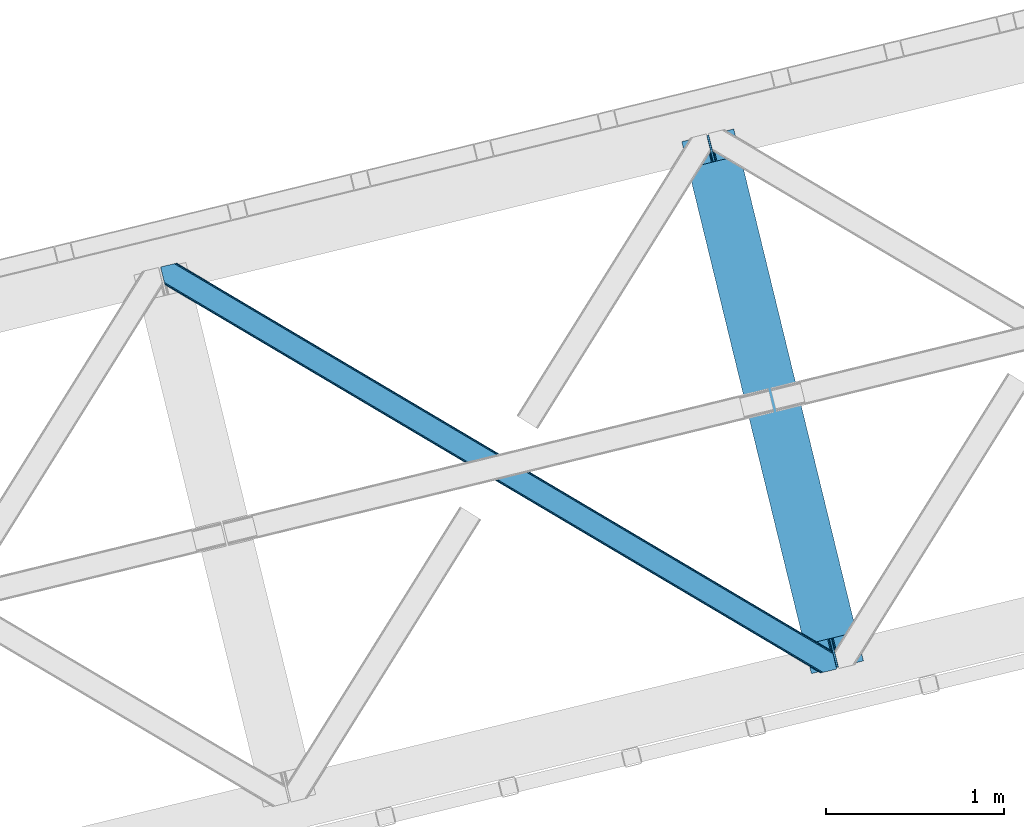
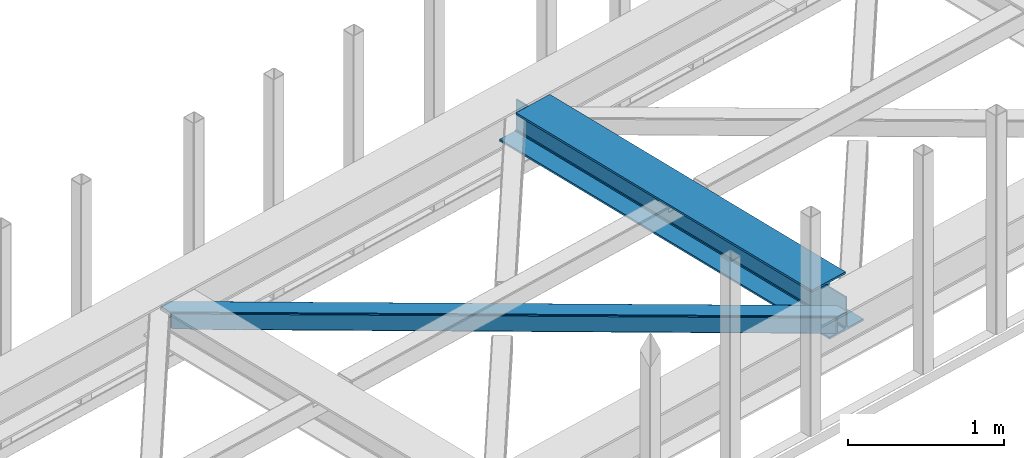
# One storey, part 47 of 67: 1 beam, 1 member.
"""IFC4 building model written with IfcOpenShell, lengths in millimetres."""

from ifc_helpers import new_model, entity, si_unit, converted_unit, derived_unit, direction, frame, origin, place, context, subcontext, project, spatial, triangles, polygons, material, type_object, element, save


model = new_model("IFC4")

# Units and contexts
model_context = context("Model", 3, precision=0.01, world=origin(), true_north=direction((6.12303176911189e-17, 1.0)))
plan_context = context("Plan", 3, precision=0.01, world=origin(), true_north=direction((6.12303176911189e-17, 1.0)))
body_context = subcontext(model_context, "Body", "Model", "MODEL_VIEW")
ifc_project = project(units=[si_unit("LENGTHUNIT", "METRE", prefix="MILLI"), si_unit("AREAUNIT", "SQUARE_METRE"), si_unit("VOLUMEUNIT", "CUBIC_METRE"), converted_unit("PLANEANGLEUNIT", "DEGREE", entity("IfcRatioMeasure", 0.0174532925199433), si_unit("PLANEANGLEUNIT", "RADIAN"), dimensions=[0, 0, 0, 0, 0, 0, 0]), si_unit("MASSUNIT", "GRAM", prefix="KILO"), derived_unit("MASSDENSITYUNIT", [(si_unit("MASSUNIT", "GRAM", prefix="KILO"), 1), (si_unit("LENGTHUNIT", "METRE"), -3)]), derived_unit("MOMENTOFINERTIAUNIT", [(si_unit("LENGTHUNIT", "METRE"), 4)]), si_unit("TIMEUNIT", "SECOND"), si_unit("FREQUENCYUNIT", "HERTZ"), si_unit("THERMODYNAMICTEMPERATUREUNIT", "DEGREE_CELSIUS"), derived_unit("THERMALTRANSMITTANCEUNIT", [(si_unit("MASSUNIT", "GRAM", prefix="KILO"), 1), (si_unit("THERMODYNAMICTEMPERATUREUNIT", "KELVIN"), -1), (si_unit("TIMEUNIT", "SECOND"), -3)]), derived_unit("VOLUMETRICFLOWRATEUNIT", [(si_unit("LENGTHUNIT", "METRE"), 3), (si_unit("TIMEUNIT", "SECOND"), -1)]), derived_unit("MASSFLOWRATEUNIT", [(si_unit("MASSUNIT", "GRAM", prefix="KILO"), 1), (si_unit("TIMEUNIT", "SECOND"), -1)]), derived_unit("ROTATIONALFREQUENCYUNIT", [(si_unit("TIMEUNIT", "SECOND"), -1)]), si_unit("ELECTRICCURRENTUNIT", "AMPERE"), si_unit("ELECTRICVOLTAGEUNIT", "VOLT"), si_unit("POWERUNIT", "WATT"), si_unit("FORCEUNIT", "NEWTON", prefix="KILO"), si_unit("ILLUMINANCEUNIT", "LUX"), si_unit("LUMINOUSFLUXUNIT", "LUMEN"), si_unit("LUMINOUSINTENSITYUNIT", "CANDELA"), derived_unit("USERDEFINED", [(si_unit("MASSUNIT", "GRAM", prefix="KILO"), -1), (si_unit("LENGTHUNIT", "METRE"), -2), (si_unit("TIMEUNIT", "SECOND"), 3), (si_unit("LUMINOUSFLUXUNIT", "LUMEN"), 1)]), derived_unit("LINEARVELOCITYUNIT", [(si_unit("LENGTHUNIT", "METRE"), 1), (si_unit("TIMEUNIT", "SECOND"), -1)]), si_unit("PRESSUREUNIT", "PASCAL"), derived_unit("USERDEFINED", [(si_unit("LENGTHUNIT", "METRE"), -2), (si_unit("MASSUNIT", "GRAM", prefix="KILO"), 1), (si_unit("TIMEUNIT", "SECOND"), -2)]), derived_unit("LINEARFORCEUNIT", [(si_unit("MASSUNIT", "GRAM", prefix="KILO"), 1), (si_unit("LENGTHUNIT", "METRE"), 1), (si_unit("TIMEUNIT", "SECOND"), -2), (si_unit("LENGTHUNIT", "METRE"), -1)]), derived_unit("PLANARFORCEUNIT", [(si_unit("MASSUNIT", "GRAM", prefix="KILO"), 1), (si_unit("LENGTHUNIT", "METRE"), 1), (si_unit("TIMEUNIT", "SECOND"), -2), (si_unit("LENGTHUNIT", "METRE"), -2)])], contexts=[model_context, plan_context])

# Site, building, storey
site_placement = place(None, origin())
site = spatial("IfcSite", under=ifc_project, at=site_placement, CompositionType="ELEMENT")
building_placement = place(site_placement, origin())
building = spatial("IfcBuilding", under=site, at=building_placement, CompositionType="ELEMENT")
storey_placement = place(building_placement, frame((0.0, 0.0, 19800.0)))
storey = spatial("IfcBuildingStorey", under=building, at=storey_placement, CompositionType="ELEMENT", Elevation=19800.0)

# Beam
ifc_material = material(Name="Metal painted (White)")
beam_type = type_object("IfcBeamType", PredefinedType="BEAM")
beam_placement = place(storey_placement, frame((-14954.5071311778, 14149.6098838578, 3807.02022389142)))
element("IfcBeam", 1, at=beam_placement, inside=storey, type_object=beam_type, material=ifc_material, ObjectType="Steel Beam", PredefinedType="BEAM", context=body_context, shape_type="Tessellation", body=[
    polygons([(1018.1664837833, 71.0478278971043, 15.5000000000008), (1018.16648378329, 71.0478278971043, 0.0), (291.465617442446, 3052.25531830422, 0.0), (291.465617442448, 3052.25531830422, 15.5000000000008), (894.779372399329, 40.9709140873291, 15.5000000000008), (168.078506058476, 3022.17840449444, 15.5000000000008), (888.087028625377, 39.3395844888265, 16.8701684147984), (161.386162284526, 3020.54707489594, 16.8701684147984), (882.413533524757, 37.9566100336519, 20.7720779386434), (155.712667183904, 3019.16410044077, 20.7720779386434), (878.622625296178, 37.0325360459162, 26.6116982174294), (151.921758955329, 3018.24002645303, 26.6116982174294), (877.291435352781, 36.7080444135051, 33.500000000001), (150.59056901193, 3017.91553482062, 33.500000000001), (140.875048430516, 3015.54727389071, 33.500000000001), (140.875048430512, 3015.54727389071, 259.000000000002), (150.590569011935, 3017.91553482062, 259.000000000002), (0.0, 2981.20749040711, 0.0), (0.0, 2981.20749040711, 15.4999999999965), (123.387111383964, 3011.28440421689, 15.5000000000008), (130.079455157924, 3012.91573381539, 16.8701684147941), (135.752950258549, 3014.29870827056, 20.7720779386434), (139.543858487119, 3015.2227822583, 26.6116982174294), (877.291435352788, 36.7080444135051, 259.000000000002), (867.575914771362, 34.3397834835992, 259.000000000002), (867.575914771367, 34.3397834835992, 33.500000000001), (866.24472482797, 34.0152918511859, 26.6116982174294), (862.453816599399, 33.0912178634524, 20.7720779386434), (856.780321498773, 31.70824340828, 16.8701684147941), (850.087977724817, 30.0769138097752, 15.5000000000008), (726.700866340853, 2.16573425859679e-12, 15.4999999999965), (726.700866340853, 2.16573425859679e-12, 0.0), (838.124523615921, 197.385937999185, 259.069791973884), (186.46972209998, 2870.72539801219, 259.000000000002), (186.693115201831, 2869.80895360721, 259.617303331124), (186.705504045461, 2869.75812937344, 266.500003008253), (837.979344808156, 197.981416001706, 266.500002998871), (837.979694928908, 197.979979696975, 260.000004007589), (828.499586345868, 194.645865944432, 259.006343171919), (828.276216326105, 195.562317481911, 259.617303331124), (828.263827482477, 195.613141715687, 266.500003008253), (176.989986719777, 2867.38985508742, 266.500002998871), (176.989636599025, 2867.39129139215, 260.000004007589), (176.844830940683, 2867.98534020594, 259.07612046749), (176.754201518552, 2868.35713708228, 259.000000000002), (839.310832678068, 198.30468544639, 273.388305639783), (843.101109266764, 199.231350618306, 279.227924098781), (848.7741802143, 200.616065081981, 283.129832400619), (855.466371895425, 202.248018612794, 284.500000377224), (978.853400583271, 232.325271667903, 284.500000138971), (978.85173077662, 232.332121736637, 299.999995328161), (687.386308679347, 161.283492472596, 299.999995890962), (687.387978485999, 161.276642403865, 284.500000701776), (810.775007173843, 191.353895458974, 284.500000463519), (817.467494069984, 192.984637925553, 283.129832461069), (823.141405718757, 194.365903570081, 279.227924137322), (826.93294050574, 195.287407219377, 273.388305663684), (175.658498849859, 2867.06658564273, 273.388305639783), (171.868222261169, 2866.13992047082, 279.227924098781), (166.195151313624, 2864.75520600714, 283.129832400619), (159.502959632495, 2863.12325247633, 284.500000377228), (36.1159309446555, 2833.04599942122, 284.500000138971), (36.117600751305, 2833.03914935249, 299.999995328161), (327.583022848578, 2904.08777861653, 299.999995890962), (327.58135304193, 2904.09462868526, 284.500000701776), (204.194324354077, 2874.01737563015, 284.500000463519), (197.501837457941, 2872.38663316357, 283.129832461069), (191.827925809181, 2871.00536751905, 279.227924137322), (188.036391022187, 2870.08386386975, 273.388305663684)], [[[1, 2, 3, 4]], [[5, 1, 4, 6]], [[7, 5, 6, 8]], [[9, 7, 8, 10]], [[11, 9, 10, 12]], [[13, 11, 12, 14]], [[15, 16, 17, 14, 12, 10, 8, 6, 4, 3, 18, 19, 20, 21, 22, 23]], [[13, 24, 25, 26, 27, 28, 29, 30, 31, 32, 2, 1, 5, 7, 9, 11]], [[2, 32, 18, 3]], [[32, 31, 19, 18]], [[31, 30, 20, 19]], [[27, 26, 15, 23]], [[28, 27, 23, 22]], [[29, 28, 22, 21]], [[30, 29, 21, 20]], [[33, 24, 13, 14, 17, 34, 35, 36, 37, 38]], [[25, 39, 40, 41, 42, 43, 44, 16, 15, 26]], [[39, 25, 24, 33]], [[45, 34, 17, 16]], [[41, 40, 38, 37, 46, 47, 48, 49, 50, 51, 52, 53, 54, 55, 56, 57]], [[42, 58, 59, 60, 61, 62, 63, 64, 65, 66, 67, 68, 69, 36, 35, 43]], [[46, 37, 36, 69]], [[47, 46, 69, 68]], [[48, 47, 68, 67]], [[49, 48, 67, 66]], [[50, 49, 66, 65]], [[51, 50, 65, 64]], [[52, 51, 64, 63]], [[53, 52, 63, 62]], [[54, 53, 62, 61]], [[55, 54, 61, 60]], [[56, 55, 60, 59]], [[57, 56, 59, 58]], [[41, 57, 58, 42]]], closed=False),
])

# Member
member_type = type_object("IfcMemberType", PredefinedType="BRACE")
member_placement = place(storey_placement, frame((-17875.1786865234, 14152.6640441895, 3822.99993896484)))
element("IfcMember", 2, at=member_placement, inside=storey, type_object=member_type, ObjectType="Steel Horizontal Brace", PredefinedType="BRACE", context=body_context, shape_type="Tessellation", body=[
    triangles([(3167.12412414551, 476.930191040039, 17.5012573242202), (3764.84577941895, 123.065744018553, 122.499499511719), (3764.84577941895, 123.065744018553, 17.5012573242202), (2547.33172302246, 843.862445068358, 17.5012573242202), (1927.53932189941, 1210.79469909668, 17.5012573242202), (91.5002288818359, 2297.77602539063, 122.499499511719), (687.954519653322, 1944.65804443359, 17.5012573242202), (91.5002288818359, 2297.77602539063, 17.5012573242202), (1307.74692077637, 1577.726953125, 17.5012573242202), (3770.63961181641, 99.2985900878903, 140.00075683594), (3768.42230529785, 108.393383789062, 138.668280029298), (76.4767272949211, 2294.11345825195, 138.668280029298), (67.1679931640647, 2291.84499206543, 140.00075683594), (3766.54335021973, 116.104541015624, 134.87548828125), (84.3704315185569, 2296.03775939941, 134.87548828125), (3765.28761291504, 121.256552124023, 129.196765136719), (89.6480163574233, 2297.32489013672, 129.196765136719), (3722.23907775879, 5.93219604492151, 140.00075683594), (18.767459106446, 2198.47859802246, 140.00075683594), (3789.40707092285, 22.304452514647, 140.00075683594), (0.0, 2275.47157287597, 140.00075683594), (3697.90684204102, 0.0, 122.499499511719), (3699.75905456543, 0.452297973632085, 129.196765136719), (24.1194580078118, 2176.52063598633, 129.196765136719), (24.5612915039055, 2174.7114440918, 122.499499511719), (3705.03198852539, 1.73710327148365, 134.87548828125), (22.8637207031243, 2181.67264709473, 134.87548828125), (3712.92685546875, 3.66140441894458, 138.668280029298), (20.9847656250022, 2189.38264160156, 138.668280029298), (1862.08168945313, 1086.85342712402, 17.5012573242202), (2481.93571472168, 719.882803344726, 17.5012573242202), (3101.79555358887, 352.912179565428, 17.5012573242202), (3697.90684204102, 0.0, 17.5012573242202), (1242.22185058594, 1453.82405090332, 17.5012573242202), (622.367825317382, 1820.79467468262, 17.5012573242202), (24.5612915039055, 2174.7114440918, 17.5012573242202), (74.6373046875015, 2293.66581115723, 127.873590087893), (66.7436004638694, 2291.74151000977, 131.668707275392), (79.9148895263679, 2294.95177917481, 122.197192382813), (57.4348663330093, 2289.47304382324, 133.001184082033), (0.0, 2275.47157287597, 133.001184082033), (81.7671020507805, 2295.40407714844, 115.499926757813), (81.7671020507805, 2295.40407714844, 24.5008300781265), (79.9148895263679, 2294.95177917481, 17.8035644531265), (89.5573242187493, 2297.30279846191, 10.8156188964858), (89.4666320800789, 2297.28070678711, 10.4993591308594), (74.112918090821, 2293.53791198731, 12.4271484375022), (72.0339752197287, 2293.03096618652, 10.4993591308594), (1922.19081115723, 1205.8275604248, 24.5008300781265), (3767.16307983398, 113.558184814452, 115.499926757813), (2545.10627746582, 837.045419311524, 24.5008300781265), (3168.02523193359, 468.264440917968, 24.5008300781265), (3767.16307983398, 113.558184814452, 24.5008300781265), (1299.27185668945, 1574.60970153809, 24.5008300781265), (676.357553100588, 1943.39184265137, 24.5008300781265), (3767.60491333008, 111.750155639647, 122.197192382813), (3768.86065063477, 106.59814453125, 127.873590087893), (3770.73960571289, 98.886987304686, 131.668707275392), (3772.95691223145, 89.7921936035145, 133.001184082033), (3767.6932800293, 111.386224365233, 17.8686767578147), (3767.80141296387, 110.944390869139, 16.5199218750022), (3764.85508117676, 123.028536987304, 16.5199218750022), (3789.40707092285, 22.304452514647, 133.001184082033), (3731.97220458985, 8.30414428710901, 133.001184082033), (16.4501586914084, 2207.98499450684, 133.001184082033), (162.736578369142, 2253.90544738769, 10.4993591308594), (166.88748779297, 2236.87625427246, 10.4993591308594), (3722.65881958008, 6.03451538085938, 131.668707275392), (18.6674652099609, 2198.89020080566, 131.668707275392), (3714.76511535645, 4.11021423339844, 127.873590087893), (20.5464202880867, 2191.1790435791, 127.873590087893), (3709.49218139648, 2.82424621581958, 122.197192382813), (21.8021575927742, 2186.0270324707, 122.197192382813), (3707.63996887207, 2.37311096191297, 115.499926757813), (22.2439910888679, 2184.21784057617, 115.499926757813), (3114.18549499512, 353.713293457031, 24.5008300781265), (3707.63996887207, 2.37311096191297, 24.5008300781265), (2491.11538696289, 722.583801269531, 24.5008300781265), (1868.04992980957, 1091.45430908203, 24.5008300781265), (621.919015502932, 1829.19648742676, 24.5008300781265), (22.2439910888679, 2184.21784057617, 24.5008300781265), (1244.98447265625, 1460.32597961426, 24.5008300781265), (3709.49218139648, 2.82424621581958, 17.8035644531265), (3700.1299621582, 0.542990112304324, 10.8691040039084), (3700.58109741211, 0.652285766600471, 9.52034912109593), (3714.76511535645, 4.11021423339844, 12.1248413085959), (3719.39273986816, 5.23805236816406, 9.52034912109593), (21.7812286376975, 2186.11307373047, 17.817517089843), (21.7602996826172, 2186.20260314941, 17.5012573242202), (32.132922363282, 2171.84650268555, 10.8179443359368), (28.3459442138665, 2188.73965759277, 10.4993591308594), (27.0088165283196, 2187.35137023926, 12.1248413085959), (32.4968536376946, 2171.71046447754, 10.4993591308594), (203.965457153321, 2084.76925964355, 10.4993591308594), (208.116366577149, 2067.74006652832, 10.4993591308594), (164.09696044922, 2252.5485534668, 9.49942016601563), (168.582733154297, 2234.14618835449, 9.49942016601563), (168.164154052734, 2234.81824035644, 9.74591674804833), (163.767910766601, 2252.87644042969, 9.74126586914281), (167.732785034179, 2235.51005859375, 9.9993896484375), (163.414443969727, 2253.22641906738, 9.9993896484375), (167.304904174805, 2236.20303955078, 10.2528625488303), (163.060977172852, 2253.5775604248, 10.2598388671868), (209.161651611328, 2067.67262878418, 9.49942016601563), (209.130258178713, 2067.46682739258, 9.88311767578125), (204.677041625979, 2085.44363708496, 9.8528869628899), (208.802371215821, 2067.55635681152, 10.0831054687515), (204.682855224612, 2084.81228027344, 10.2063537597678), (208.444253540041, 2067.65053710938, 10.2993713378928), (204.323574829101, 2084.79018859863, 10.3528564453118), (204.675878906251, 2086.07615661621, 9.49942016601563), (3763.57376403809, 109.727023315429, 12.1248413085959), (3758.56593017578, 124.97144165039, 10.8714294433594), (3757.06369628906, 125.435366821288, 9.52034912109593), (3761.54249267578, 107.0643951416, 9.52034912109593), (3585.92297973633, 211.034793090819, 9.52034912109593), (3581.44418334961, 229.406927490234, 9.52034912109593), (3585.50556335449, 211.134786987304, 9.44360961914208), (3581.04420776367, 229.55343017578, 9.37384643554833), (3580.64539489746, 229.701095581055, 9.22734375000073), (3580.53261108399, 229.532501220703, 8.87387695312646), (3585.45556640625, 210.477850341797, 9.13897705078125), (3580.42564086914, 229.366232299804, 8.52041015625218), (3585.40324401856, 209.805798339843, 8.82736816406396), (3585.35324707031, 209.148861694335, 8.52041015625218), (3164.51265563965, 472.519995117187, 5.12526855468968), (3581.30116882324, 225.772265624999, 5.12526855468968), (3166.44625854492, 475.784912109375, 10.8039916992202), (687.27549133301, 1943.51276550293, 10.8039916992202), (685.343051147462, 1940.24784851074, 5.12526855468968), (165.152709960938, 2248.21625976563, 5.12526855468968), (682.450204467776, 1935.36210021973, 1.33247680664135), (167.031665039063, 2240.50626525879, 1.33247680664135), (679.039947509766, 1929.59966125488, 0.0), (169.248971557619, 2231.41030883789, 0.0), (3583.18128662109, 218.061108398437, 1.33247680664135), (3585.39743041992, 208.966314697265, 0.0), (3158.20955200195, 461.871807861327, 0.0), (3161.62097167969, 467.634246826172, 1.33247680664135), (2546.65385742188, 842.716003417969, 10.8039916992202), (1926.86145629883, 1209.64825744629, 10.8039916992202), (1307.06789245606, 1576.58051147461, 10.8039916992202), (2544.7202545166, 839.452249145508, 5.12526855468968), (1924.92785339356, 1206.38450317383, 5.12526855468968), (1305.13545227051, 1573.31559448242, 5.12526855468968), (2541.82857055664, 834.566500854491, 1.33247680664135), (1922.03500671387, 1201.49875488281, 1.33247680664135), (1302.24260559082, 1568.43100891113, 1.33247680664135), (2538.41715087891, 828.804061889648, 0.0), (1918.62474975586, 1195.73631591797, 0.0), (1298.83234863281, 1562.66740722656, 0.0), (3620.15809936524, 66.3668792724602, 0.0), (3110.71012573242, 367.971725463867, 0.0), (2490.85493774414, 734.942349243163, 0.0), (1870.99626159668, 1101.91297302246, 0.0), (631.282397460938, 1835.85422058105, 0.0), (1251.13642272949, 1468.88243408203, 0.0), (204.009640502929, 2088.81087341309, 0.0), (3167.34736633301, 467.117999267577, 17.8035644531265), (3165.41492614746, 463.853082275389, 12.1248413085959), (673.746084594728, 1938.98164672851, 12.1248413085959), (675.6796875, 1942.24540100098, 17.8035644531265), (670.854400634766, 1934.0958984375, 8.3320495605476), (169.397799682618, 2230.8022064209, 8.81806640624927), (171.566271972657, 2221.90391235351, 6.99957275390625), (3159.11065979004, 453.206057739257, 6.99957275390625), (3587.71473083496, 199.45991821289, 6.99957275390625), (3585.50556335449, 208.525643920897, 8.42274169921802), (3162.52207946777, 458.968496704101, 8.3320495605476), (667.442980957032, 1928.33345947266, 6.99957275390625), (2536.19170532227, 821.987036132812, 6.99957275390625), (2539.603125, 827.749475097657, 8.3320495605476), (1913.2774017334, 1190.76917724609, 6.99957275390625), (1916.68765869141, 1196.53161621094, 8.3320495605476), (1290.3572845459, 1559.55015563965, 6.99957275390625), (1293.76870422363, 1565.31259460449, 8.3320495605476), (2542.49480895996, 832.635223388672, 12.1248413085959), (1919.58050537109, 1201.41736450195, 12.1248413085959), (1296.66155090332, 1570.19834289551, 12.1248413085959), (2544.42841186524, 835.898977661132, 17.8035644531265), (1921.51294555664, 1204.68228149414, 17.8035644531265), (1298.59399108887, 1573.46325988769, 17.8035644531265), (201.692340087891, 2098.31726989746, 6.99957275390625), (203.86081237793, 2089.41897583008, 8.81806640624927), (206.225784301758, 2079.71491699219, 1.33247680664135), (208.105902099611, 2072.00492248535, 5.12526855468968), (2500.02995910645, 737.642184448241, 6.99957275390625), (3123.10006713867, 368.771676635741, 6.99957275390625), (1876.96450195313, 1106.51269226074, 6.99957275390625), (3617.8407989502, 75.8732757568359, 6.99957275390625), (630.832424926757, 1844.25487060547, 6.99957275390625), (1253.8990447998, 1475.38436279297, 6.99957275390625), (3119.68864746094, 363.009237670898, 8.3320495605476), (3620.55807495117, 65.0402160644517, 8.90410766601781), (3620.20228271484, 66.1843322753903, 8.52041015625218), (3116.79580078125, 358.124652099608, 12.1248413085959), (3621.04874267578, 64.3216552734375, 9.1087463378899), (3621.54754943848, 63.5926300048814, 9.31571044922021), (3622.03821716309, 62.8740692138672, 9.52034912109593), (3620.04996643066, 66.8075500488267, 8.42274169921802), (624.529321289065, 1833.60668334961, 12.1248413085959), (627.422167968751, 1838.49243164063, 8.3320495605476), (622.596881103516, 1830.34292907715, 17.8035644531265), (3114.8633605957, 354.85973510742, 17.8035644531265), (2491.79325256348, 723.730242919921, 17.8035644531265), (1868.72779541016, 1092.60075073242, 17.8035644531265), (1245.66233825684, 1461.47125854492, 17.8035644531265), (2493.72569274902, 726.993997192383, 12.1248413085959), (1870.6602355957, 1095.86450500488, 12.1248413085959), (1247.59477844238, 1464.73617553711, 12.1248413085959), (2496.61853942871, 731.879745483398, 8.3320495605476), (1873.55308227539, 1100.7502532959, 8.3320495605476), (1250.48762512207, 1469.62192382812, 8.3320495605476), (3102.47341918945, 354.05862121582, 10.8039916992202), (624.978131103515, 1825.2060333252, 5.12526855468968), (623.04569091797, 1821.94111633301, 10.8039916992202), (3626.51701354981, 44.5019348144524, 9.52034912109593), (3104.405859375, 357.323538208007, 5.12526855468968), (3624.25436096192, 49.5609283447266, 5.12526855468968), (3625.13105163574, 45.9669616699211, 8.52041015625218), (3625.82170715332, 45.2344482421868, 9.02037963867406), (3622.37540588379, 57.2709228515614, 1.33247680664135), (3107.29870605469, 362.208123779295, 1.33247680664135), (627.870977783205, 1830.09178161621, 1.33247680664135), (2487.4388671875, 729.178747558593, 1.33247680664135), (1867.58484191895, 1096.14937133789, 1.33247680664135), (1247.72616577148, 1463.11999511719, 1.33247680664135), (2484.54718322754, 724.292999267578, 5.12526855468968), (1864.69199523926, 1091.2647857666, 5.12526855468968), (1244.8333190918, 1458.23424682617, 5.12526855468968), (2482.61823120117, 721.030407714843, 10.8039916992202), (1862.75955505371, 1087.99986877441, 10.8039916992202), (1242.89971618652, 1454.97049255371, 10.8039916992202)], [[1, 2, 3], [2, 1, 4], [2, 5, 6], [5, 2, 4], [7, 8, 6], [9, 6, 5], [6, 9, 7], [10, 11, 12], [12, 13, 10], [11, 14, 15], [15, 12, 11], [14, 16, 17], [17, 15, 14], [16, 2, 6], [6, 17, 16], [18, 10, 19], [18, 20, 10], [13, 19, 10], [21, 19, 13], [22, 23, 24], [24, 25, 22], [23, 26, 27], [27, 24, 23], [26, 28, 29], [29, 27, 26], [28, 18, 19], [19, 29, 28], [30, 22, 25], [22, 31, 32], [30, 31, 22], [32, 33, 22], [34, 25, 35], [25, 34, 30], [36, 35, 25], [37, 38, 12], [15, 37, 12], [15, 17, 39], [37, 15, 39], [39, 17, 6], [38, 13, 12], [21, 40, 41], [21, 13, 40], [38, 40, 13], [39, 6, 42], [43, 8, 44], [6, 43, 42], [8, 45, 44], [6, 8, 43], [46, 44, 45], [46, 47, 44], [46, 48, 47], [49, 50, 42], [50, 51, 52], [49, 51, 50], [52, 53, 50], [54, 42, 55], [42, 54, 49], [43, 55, 42], [50, 56, 42], [39, 42, 56], [56, 57, 39], [37, 39, 57], [57, 58, 37], [38, 37, 58], [58, 59, 38], [40, 38, 59], [57, 14, 11], [59, 58, 10], [58, 57, 11], [60, 61, 62], [63, 59, 20], [10, 20, 59], [58, 11, 10], [60, 3, 53], [2, 50, 53], [53, 3, 2], [60, 62, 3], [2, 56, 50], [56, 14, 57], [14, 56, 16], [2, 16, 56], [59, 64, 65], [64, 59, 63], [65, 40, 59], [41, 40, 65], [66, 67, 46], [48, 46, 67], [64, 68, 65], [69, 65, 68], [68, 70, 69], [71, 69, 70], [70, 72, 71], [73, 71, 72], [72, 74, 73], [75, 73, 74], [76, 74, 77], [74, 76, 78], [74, 79, 75], [79, 74, 78], [80, 81, 75], [82, 75, 79], [75, 82, 80], [70, 68, 28], [26, 70, 28], [26, 23, 72], [70, 26, 72], [72, 23, 22], [68, 18, 28], [20, 64, 63], [20, 18, 64], [68, 64, 18], [72, 22, 74], [77, 33, 83], [22, 77, 74], [33, 84, 83], [22, 33, 77], [85, 83, 84], [86, 83, 85], [87, 86, 85], [73, 75, 25], [25, 24, 73], [27, 73, 24], [73, 27, 71], [25, 81, 36], [88, 89, 36], [36, 81, 88], [75, 81, 25], [69, 29, 19], [21, 65, 19], [41, 65, 21], [69, 71, 29], [29, 71, 27], [65, 69, 19], [90, 91, 92], [90, 93, 91], [92, 36, 90], [89, 36, 92], [94, 95, 93], [93, 91, 94], [96, 97, 98], [98, 99, 96], [99, 98, 100], [100, 101, 99], [101, 100, 102], [102, 103, 101], [103, 102, 67], [67, 66, 103], [104, 105, 106], [105, 107, 108], [108, 107, 109], [110, 109, 95], [95, 94, 110], [109, 110, 108], [108, 106, 105], [106, 111, 104], [62, 112, 113], [112, 62, 61], [112, 114, 113], [112, 115, 114], [114, 115, 116], [116, 117, 114], [118, 119, 117], [120, 119, 118], [121, 120, 122], [123, 121, 124], [124, 125, 123], [122, 124, 121], [118, 122, 120], [117, 116, 118], [1, 3, 113], [3, 62, 113], [120, 121, 126], [123, 126, 121], [123, 127, 126], [128, 113, 117], [117, 126, 128], [117, 119, 126], [120, 126, 119], [113, 114, 117], [45, 129, 66], [129, 130, 131], [131, 96, 129], [129, 99, 101], [99, 129, 96], [129, 103, 66], [103, 129, 101], [129, 45, 8], [8, 7, 129], [66, 46, 45], [130, 132, 133], [133, 131, 130], [132, 134, 135], [135, 133, 132], [136, 137, 138], [138, 139, 136], [127, 136, 139], [139, 126, 127], [113, 128, 1], [1, 128, 4], [140, 4, 128], [4, 140, 141], [141, 5, 4], [5, 141, 142], [142, 9, 5], [9, 142, 129], [129, 7, 9], [128, 126, 143], [143, 140, 128], [140, 143, 141], [144, 141, 143], [141, 144, 142], [145, 142, 144], [142, 145, 129], [130, 129, 145], [126, 139, 146], [146, 143, 126], [143, 146, 147], [147, 144, 143], [144, 147, 145], [148, 145, 147], [145, 148, 130], [132, 130, 148], [139, 138, 146], [149, 146, 138], [146, 149, 147], [150, 147, 149], [147, 150, 148], [151, 148, 150], [148, 151, 134], [134, 132, 148], [137, 152, 153], [138, 153, 154], [153, 138, 137], [149, 155, 150], [154, 149, 138], [149, 154, 155], [156, 134, 151], [150, 157, 151], [157, 150, 155], [157, 156, 151], [158, 134, 156], [135, 134, 158], [159, 160, 112], [112, 61, 159], [159, 60, 53], [161, 162, 44], [98, 163, 100], [98, 97, 163], [163, 102, 100], [163, 67, 102], [97, 164, 163], [161, 47, 67], [67, 163, 161], [47, 48, 67], [163, 164, 165], [166, 167, 168], [160, 118, 116], [116, 112, 160], [116, 115, 112], [169, 168, 125], [125, 160, 169], [124, 122, 160], [122, 118, 160], [160, 125, 124], [168, 169, 166], [165, 170, 163], [44, 47, 161], [162, 55, 43], [43, 44, 162], [53, 52, 159], [61, 60, 159], [166, 169, 171], [172, 171, 169], [171, 172, 173], [174, 173, 172], [173, 174, 175], [176, 175, 174], [175, 176, 163], [163, 170, 175], [169, 160, 177], [177, 172, 169], [172, 177, 178], [178, 174, 172], [174, 178, 179], [179, 176, 174], [176, 179, 163], [161, 163, 179], [160, 159, 177], [180, 177, 159], [177, 180, 178], [181, 178, 180], [178, 181, 179], [182, 179, 181], [179, 182, 161], [162, 161, 182], [159, 52, 180], [51, 180, 52], [180, 51, 49], [49, 181, 180], [181, 49, 182], [54, 182, 49], [182, 54, 162], [55, 162, 54], [97, 131, 133], [135, 97, 133], [165, 164, 135], [165, 135, 183], [131, 97, 96], [135, 164, 97], [183, 158, 184], [158, 185, 111], [158, 183, 135], [186, 111, 185], [158, 111, 184], [186, 104, 111], [187, 188, 166], [166, 171, 187], [171, 189, 187], [189, 171, 173], [188, 167, 166], [188, 190, 167], [170, 191, 175], [191, 170, 183], [165, 183, 170], [192, 175, 191], [173, 192, 189], [175, 192, 173], [193, 194, 195], [196, 197, 194], [196, 198, 197], [196, 199, 198], [194, 193, 196], [195, 200, 193], [86, 87, 199], [199, 196, 86], [193, 200, 190], [191, 183, 184], [201, 108, 110], [110, 94, 201], [94, 92, 201], [94, 91, 92], [202, 106, 108], [202, 111, 106], [202, 184, 111], [108, 201, 202], [203, 201, 92], [92, 89, 203], [203, 88, 81], [81, 80, 203], [89, 88, 203], [184, 202, 191], [190, 188, 193], [83, 86, 196], [196, 204, 83], [77, 83, 204], [204, 76, 77], [76, 204, 78], [205, 78, 204], [78, 205, 206], [206, 79, 78], [79, 206, 207], [207, 82, 79], [82, 207, 80], [203, 80, 207], [204, 196, 208], [208, 205, 204], [205, 208, 206], [209, 206, 208], [206, 209, 210], [210, 207, 206], [207, 210, 201], [201, 203, 207], [196, 193, 208], [211, 208, 193], [208, 211, 212], [212, 209, 208], [209, 212, 213], [213, 210, 209], [210, 213, 202], [202, 201, 210], [193, 188, 211], [187, 211, 188], [211, 187, 212], [189, 212, 187], [212, 189, 213], [192, 213, 189], [213, 192, 191], [191, 202, 213], [214, 84, 33], [35, 36, 90], [215, 105, 104], [216, 90, 95], [95, 215, 216], [95, 107, 215], [104, 186, 215], [84, 214, 217], [214, 218, 219], [219, 220, 214], [221, 217, 214], [214, 220, 221], [217, 85, 84], [222, 219, 218], [218, 223, 222], [152, 222, 223], [223, 153, 152], [156, 224, 185], [185, 158, 156], [224, 215, 186], [186, 185, 224], [90, 216, 35], [33, 32, 214], [153, 223, 154], [225, 154, 223], [154, 225, 155], [226, 155, 225], [155, 226, 157], [227, 157, 226], [157, 227, 224], [224, 156, 157], [223, 218, 228], [228, 225, 223], [225, 228, 229], [229, 226, 225], [226, 229, 227], [230, 227, 229], [227, 230, 224], [215, 224, 230], [218, 214, 228], [231, 228, 214], [228, 231, 229], [232, 229, 231], [229, 232, 230], [233, 230, 232], [230, 233, 215], [216, 215, 233], [214, 32, 31], [31, 231, 214], [231, 31, 232], [30, 232, 31], [232, 30, 34], [34, 233, 232], [233, 34, 35], [35, 216, 233], [137, 167, 190], [125, 127, 123], [137, 125, 167], [125, 136, 127], [125, 137, 136], [152, 137, 190], [195, 152, 190], [219, 195, 220], [195, 222, 152], [195, 219, 222], [220, 195, 194], [221, 194, 197], [221, 197, 198], [217, 198, 199], [87, 85, 199], [217, 199, 85]]),
])

save(model, "model.ifc")
